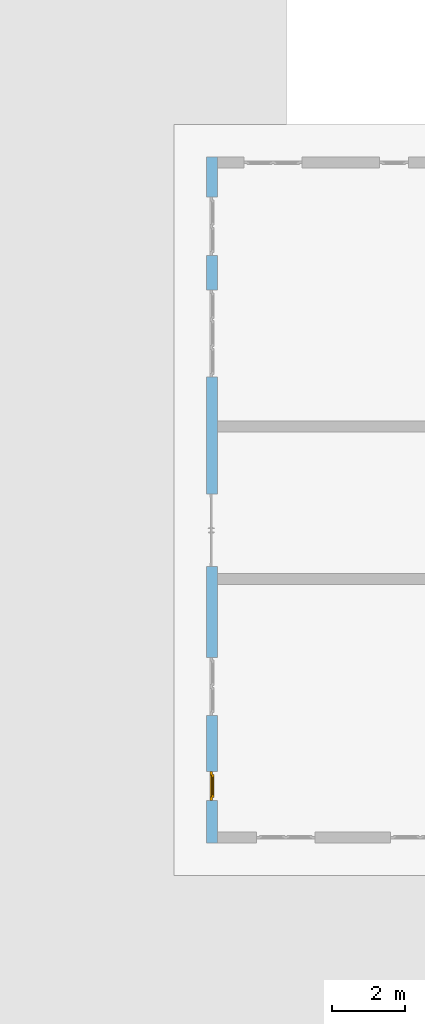
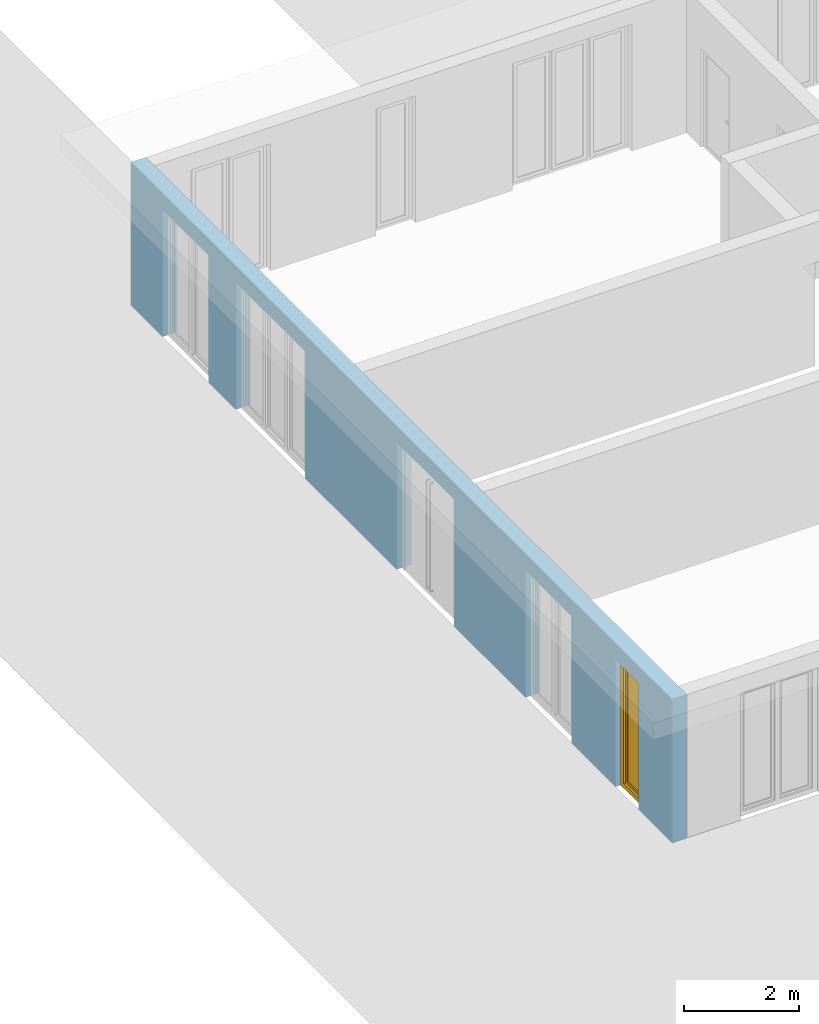
# One storey, part 10 of 23: 1 window, 5 openings, plus 1 element that does not belong to this part.
"""IFC4 building model written with IfcOpenShell, lengths in metres."""

from ifc_helpers import new_model, entity, si_unit, converted_unit, derived_unit, direction, frame, origin_with_axes, place, context, subcontext, project, spatial, polygons, source, transform, mapped, material, type_object, element, fill, save


model = new_model("IFC4")

# Units and contexts
model_context = context("Model", 3, precision=1e-05, world=origin_with_axes(), true_north=direction((0.0, 1.0)))
body_context = subcontext(model_context, "Body", "Model", "MODEL_VIEW")
ifc_project = project(units=[si_unit("LENGTHUNIT", "METRE"), si_unit("AREAUNIT", "SQUARE_METRE"), si_unit("VOLUMEUNIT", "CUBIC_METRE"), converted_unit("PLANEANGLEUNIT", "DEGREE", entity("IfcPlaneAngleMeasure", 0.0174532925199), si_unit("PLANEANGLEUNIT", "RADIAN"), dimensions=[0, 0, 0, 0, 0, 0, 0]), converted_unit("TIMEUNIT", "Year", entity("IfcTimeMeasure", 31556926.0), si_unit("TIMEUNIT", "SECOND"), dimensions=[0, 0, 1, 0, 0, 0, 0]), si_unit("MASSUNIT", "GRAM", prefix="KILO"), si_unit("THERMODYNAMICTEMPERATUREUNIT", "DEGREE_CELSIUS"), si_unit("LUMINOUSINTENSITYUNIT", "LUMEN"), si_unit("ENERGYUNIT", "JOULE", prefix="MEGA"), derived_unit("THERMALCONDUCTANCEUNIT", [(si_unit("POWERUNIT", "WATT"), 1), (si_unit("LENGTHUNIT", "METRE"), -1), (si_unit("THERMODYNAMICTEMPERATUREUNIT", "KELVIN"), -1)]), derived_unit("SPECIFICHEATCAPACITYUNIT", [(si_unit("ENERGYUNIT", "JOULE"), 1), (si_unit("MASSUNIT", "GRAM", prefix="KILO"), -1), (si_unit("THERMODYNAMICTEMPERATUREUNIT", "KELVIN"), -1)]), derived_unit("MASSDENSITYUNIT", [(si_unit("MASSUNIT", "GRAM", prefix="KILO"), 1), (si_unit("VOLUMEUNIT", "CUBIC_METRE"), -1)])], contexts=[model_context])

# Site, building, storey
site_placement = place(None, origin_with_axes())
site = spatial("IfcSite", under=ifc_project, at=site_placement, CompositionType="ELEMENT")
building_placement = place(site_placement, origin_with_axes())
building = spatial("IfcBuilding", under=site, at=building_placement, CompositionType="ELEMENT")
storey_placement = place(building_placement, origin_with_axes())
storey = spatial("IfcBuildingStorey", under=building, at=storey_placement, Name="0. Geschoss", CompositionType="ELEMENT", Elevation=0.0)

# Wall, openings, window
ifc_material = material()
wall_type = type_object("IfcWallType", Name="300", PredefinedType="NOTDEFINED")
wall_placement = place(storey_placement, frame((-11.7421993804, -9.92881223104, 0.0), z_axis=(0.0, 0.0, 1.0), x_axis=(0.0, 1.0, 0.0)))
wall = element("IfcWall", 1, at=wall_placement, inside=storey, type_object=wall_type, material=ifc_material, Name="Wand-001", PredefinedType="NOTDEFINED", context=body_context, shape_type="Tessellation", body=[
    polygons([(7.5921181063, -0.3, 0.0), (7.5921181063, -0.3, 2.7), (9.5921181063, -0.3, 2.7), (9.5921181063, -0.3, 0.0), (12.8, -0.3, 0.0), (12.8, -0.3, 2.7), (15.2, -0.3, 2.7), (15.2, -0.3, 0.0), (16.15, -0.3, 0.0), (16.15, -0.3, 2.7), (17.75, -0.3, 2.7), (17.75, -0.3, 0.0), (18.85, -0.3, 0.0), (18.85, -0.3, 3.05), (0.0, -0.3, 3.05), (0.0, -0.3, 0.0), (1.16441876325, -0.3, 0.0), (1.16441876325, -0.3, 2.7), (1.96441876325, -0.3, 2.7), (1.96441876325, -0.3, 0.0), (3.5, -0.3, 0.0), (3.5, -0.3, 2.7), (5.1, -0.3, 2.7), (5.1, -0.3, 0.0), (7.5921181063, -0.1, 0.0), (7.5921181063, -0.1, 2.7), (9.5921181063, -0.1, 2.7), (9.5921181063, -0.1, 0.0), (9.5921181063, 0.0, 0.0), (12.8, 0.0, 0.0), (12.8, -0.1, 0.0), (12.8, -0.1, 2.7), (15.2, -0.1, 2.7), (15.2, -0.1, 0.0), (15.2, 0.0, 0.0), (16.15, 0.0, 0.0), (16.15, -0.1, 0.0), (16.15, -0.1, 2.7), (17.75, -0.1, 2.7), (17.75, -0.1, 0.0), (17.75, 0.0, 0.0), (18.85, 0.0, 0.0), (18.85, 0.0, 3.05), (0.0, 0.0, 3.05), (0.0, 0.0, 0.0), (1.16441876325, 0.0, 0.0), (1.16441876325, -0.1, 0.0), (1.16441876325, -0.1, 2.7), (1.96441876325, -0.1, 2.7), (1.96441876325, -0.1, 0.0), (1.96441876325, 0.0, 0.0), (3.5, 0.0, 0.0), (3.5, -0.1, 0.0), (3.5, -0.1, 2.7), (5.1, -0.1, 2.7), (5.1, -0.1, 0.0), (5.1, 0.0, 0.0), (7.5921181063, 0.0, 0.0), (7.5921181063, 0.0, 2.7), (9.5921181063, 0.0, 2.7), (5.1, 0.0, 2.7), (3.5, 0.0, 2.7), (1.96441876325, 0.0, 2.7), (1.16441876325, 0.0, 2.7), (17.75, 0.0, 2.7), (16.15, 0.0, 2.7), (15.2, 0.0, 2.7), (12.8, 0.0, 2.7)], [[[1, 2, 3, 4, 5, 6, 7, 8, 9, 10, 11, 12, 13, 14, 15, 16, 17, 18, 19, 20, 21, 22, 23, 24]], [[2, 1, 25, 26]], [[3, 2, 26, 27]], [[4, 3, 27, 28]], [[4, 28, 29, 30, 31, 5]], [[31, 32, 6, 5]], [[32, 33, 7, 6]], [[33, 34, 8, 7]], [[8, 34, 35, 36, 37, 9]], [[10, 9, 37, 38]], [[11, 10, 38, 39]], [[12, 11, 39, 40]], [[40, 41, 42, 13, 12]], [[14, 13, 42, 43]], [[14, 43, 44, 15]], [[44, 45, 16, 15]], [[46, 47, 17, 16, 45]], [[47, 48, 18, 17]], [[48, 49, 19, 18]], [[49, 50, 20, 19]], [[20, 50, 51, 52, 53, 21]], [[22, 21, 53, 54]], [[23, 22, 54, 55]], [[24, 23, 55, 56]], [[25, 1, 24, 56, 57, 58]], [[26, 25, 58, 59]], [[27, 26, 59, 60]], [[28, 27, 60, 29]], [[30, 29, 60, 59, 58, 57, 61, 62, 52, 51, 63, 64, 46, 45, 44, 43, 42, 41, 65, 66, 36, 35, 67, 68]], [[30, 68, 32, 31]], [[68, 67, 33, 32]], [[67, 35, 34, 33]], [[38, 37, 36, 66]], [[39, 38, 66, 65]], [[40, 39, 65, 41]], [[46, 64, 48, 47]], [[64, 63, 49, 48]], [[63, 51, 50, 49]], [[54, 53, 52, 62]], [[55, 54, 62, 61]], [[56, 55, 61, 57]]], closed=True),
])
opening_1_placement = place(wall_placement, frame((16.95, 0.0, 0.0), z_axis=(0.0, 0.0, 1.0), x_axis=(1.0, 0.0, 0.0)))
element("IfcOpeningElement", 2, at=opening_1_placement, cuts=wall, Name="Fenster-001", context=body_context, identifier="Reference", shape_type="Tessellation", body=[
    polygons([(-0.8, -0.1, 0.0), (-0.8, -0.1, 2.7), (-0.8, 0.000999999999999, 2.7), (-0.8, 0.000999999999999, 0.0), (-0.8, -0.301, 0.0), (-0.8, -0.301, 2.7), (0.8, -0.1, 2.7), (0.8, 0.000999999999999, 2.7), (0.8, -0.301, 2.7), (0.8, 0.000999999999999, 0.0), (0.8, -0.1, 0.0), (0.8, -0.301, 0.0)], [[[1, 2, 3, 4]], [[2, 1, 5, 6]], [[7, 8, 3, 2, 6, 9]], [[8, 10, 4, 3]], [[1, 4, 10, 11, 12, 5]], [[6, 5, 12, 9]], [[7, 11, 10, 8]], [[11, 7, 9, 12]]], closed=True),
])
opening_2_placement = place(wall_placement, frame((14.0, 0.0, 0.0), z_axis=(0.0, 0.0, 1.0), x_axis=(1.0, 0.0, 0.0)))
element("IfcOpeningElement", 3, at=opening_2_placement, cuts=wall, Name="Fenster-002", context=body_context, identifier="Reference", shape_type="Tessellation", body=[
    polygons([(-1.2, -0.1, 0.0), (-1.2, -0.1, 2.7), (-1.2, 0.000999999999999, 2.7), (-1.2, 0.000999999999999, 0.0), (-1.2, -0.301, 0.0), (-1.2, -0.301, 2.7), (1.2, -0.1, 2.7), (1.2, 0.000999999999999, 2.7), (1.2, -0.301, 2.7), (1.2, 0.000999999999999, 0.0), (1.2, -0.1, 0.0), (1.2, -0.301, 0.0)], [[[1, 2, 3, 4]], [[2, 1, 5, 6]], [[7, 8, 3, 2, 6, 9]], [[8, 10, 4, 3]], [[1, 4, 10, 11, 12, 5]], [[6, 5, 12, 9]], [[7, 11, 10, 8]], [[11, 7, 9, 12]]], closed=True),
])
opening_3_placement = place(wall_placement, frame((4.3, 0.0, 0.0), z_axis=(0.0, 0.0, 1.0), x_axis=(1.0, 0.0, 0.0)))
element("IfcOpeningElement", 4, at=opening_3_placement, cuts=wall, Name="Fenster-001", context=body_context, identifier="Reference", shape_type="Tessellation", body=[
    polygons([(-0.8, -0.1, 0.0), (-0.8, -0.1, 2.7), (-0.8, 0.000999999999999, 2.7), (-0.8, 0.000999999999999, 0.0), (-0.8, -0.301, 0.0), (-0.8, -0.301, 2.7), (0.8, -0.1, 2.7), (0.8, 0.000999999999999, 2.7), (0.8, -0.301, 2.7), (0.8, 0.000999999999999, 0.0), (0.8, -0.1, 0.0), (0.8, -0.301, 0.0)], [[[1, 2, 3, 4]], [[2, 1, 5, 6]], [[7, 8, 3, 2, 6, 9]], [[8, 10, 4, 3]], [[1, 4, 10, 11, 12, 5]], [[6, 5, 12, 9]], [[7, 11, 10, 8]], [[11, 7, 9, 12]]], closed=True),
])
opening_4_placement = place(wall_placement, frame((1.56441876325, 0.0, 0.0), z_axis=(0.0, 0.0, 1.0), x_axis=(1.0, 0.0, 0.0)))
opening_4 = element("IfcOpeningElement", 5, at=opening_4_placement, cuts=wall, Name="Fenster-003", context=body_context, identifier="Reference", shape_type="Tessellation", body=[
    polygons([(-0.4, -0.1, 0.0), (-0.4, -0.1, 2.7), (-0.4, 0.000999999999999, 2.7), (-0.4, 0.000999999999999, 0.0), (-0.4, -0.301, 0.0), (-0.4, -0.301, 2.7), (0.4, -0.1, 2.7), (0.4, 0.000999999999999, 2.7), (0.4, -0.301, 2.7), (0.4, 0.000999999999999, 0.0), (0.4, -0.1, 0.0), (0.4, -0.301, 0.0)], [[[1, 2, 3, 4]], [[2, 1, 5, 6]], [[7, 8, 3, 2, 6, 9]], [[8, 10, 4, 3]], [[1, 4, 10, 11, 12, 5]], [[6, 5, 12, 9]], [[7, 11, 10, 8]], [[11, 7, 9, 12]]], closed=True),
])
opening_5_placement = place(wall_placement, frame((8.5921181063, 0.0, 0.0), z_axis=(0.0, 0.0, 1.0), x_axis=(1.0, 0.0, 0.0)))
element("IfcOpeningElement", 6, at=opening_5_placement, cuts=wall, context=body_context, identifier="Reference", shape_type="Tessellation", body=[
    polygons([(-1.0, -0.1, 0.0), (-1.0, -0.1, 2.7), (-1.0, 0.000999999999999, 2.7), (-1.0, 0.000999999999999, 0.0), (-1.0, -0.301, 0.0), (-1.0, -0.301, 2.7), (1.0, -0.1, 2.7), (1.0, 0.000999999999999, 2.7), (1.0, -0.301, 2.7), (1.0, 0.000999999999999, 0.0), (1.0, -0.1, 0.0), (1.0, -0.301, 0.0)], [[[1, 2, 3, 4]], [[2, 1, 5, 6]], [[7, 8, 3, 2, 6, 9]], [[8, 10, 4, 3]], [[1, 4, 10, 11, 12, 5]], [[6, 5, 12, 9]], [[7, 11, 10, 8]], [[11, 7, 9, 12]]], closed=True),
])
window_type = type_object("IfcWindowType", Name="1-26", PartitioningType="SINGLE_PANEL", PredefinedType="WINDOW")
shared_shape = source(origin_with_axes(), body_context, "Body", "Tessellation", [
    polygons([(-0.4, -0.07, 0.0), (-0.4, 0.0, 0.0), (-0.3, 0.0, 0.1), (-0.3, -0.07, 0.1), (-0.4, -0.07, 2.7), (-0.4, 0.0, 2.7), (-0.3, 0.0, 2.6), (-0.3, -0.07, 2.6)], [[[1, 2, 3, 4]], [[5, 6, 2, 1]], [[2, 6, 7, 3]], [[4, 3, 7, 8]], [[1, 4, 8, 5]], [[8, 7, 6, 5]]], closed=True),
    polygons([(0.4, -0.07, 0.0), (0.4, 0.0, 0.0), (0.4, 0.0, 2.7), (0.4, -0.07, 2.7), (0.3, -0.07, 0.1), (0.3, 0.0, 0.1), (0.3, 0.0, 2.6), (0.3, -0.07, 2.6)], [[[1, 2, 3, 4]], [[5, 6, 2, 1]], [[2, 6, 7, 3]], [[4, 3, 7, 8]], [[1, 4, 8, 5]], [[8, 7, 6, 5]]], closed=True),
    polygons([(-0.4, -0.07, 0.0), (-0.4, 0.0, 0.0), (0.4, 0.0, 0.0), (0.4, -0.07, 0.0), (-0.3, -0.07, 0.1), (-0.3, 0.0, 0.1), (0.0, 0.0, 0.1), (0.3, 0.0, 0.1), (0.3, -0.07, 0.1), (0.0, -0.07, 0.1)], [[[1, 2, 3, 4]], [[5, 6, 2, 1]], [[2, 6, 7, 8, 3]], [[4, 3, 8, 9]], [[1, 4, 9, 10, 5]], [[10, 7, 6, 5]], [[9, 8, 7, 10]]], closed=True),
    polygons([(-0.4, -0.07, 2.7), (-0.4, 0.0, 2.7), (-0.3, 0.0, 2.6), (-0.3, -0.07, 2.6), (0.4, -0.07, 2.7), (0.4, 0.0, 2.7), (0.3, 0.0, 2.6), (0.0, 0.0, 2.6), (0.0, -0.07, 2.6), (0.3, -0.07, 2.6)], [[[1, 2, 3, 4]], [[5, 6, 2, 1]], [[2, 6, 7, 8, 3]], [[4, 3, 8, 9]], [[1, 4, 9, 10, 5]], [[10, 7, 6, 5]], [[9, 8, 7, 10]]], closed=True),
    polygons([(-0.32, 0.0, 0.08), (-0.32, 0.03, 0.08), (-0.25, 0.03, 0.15), (-0.25, 0.0, 0.15), (-0.32, 0.0, 2.62), (-0.32, 0.03, 2.62), (-0.25, 0.03, 2.55), (-0.25, 0.0, 2.55)], [[[1, 2, 3, 4]], [[5, 6, 2, 1]], [[2, 6, 7, 3]], [[4, 3, 7, 8]], [[1, 4, 8, 5]], [[8, 7, 6, 5]]], closed=True),
    polygons([(0.32, 0.0, 0.08), (0.25, 0.0, 0.15), (0.25, 0.03, 0.15), (0.32, 0.03, 0.08), (0.32, 0.0, 2.62), (0.25, 0.0, 2.55), (0.25, 0.03, 2.55), (0.32, 0.03, 2.62)], [[[1, 2, 3, 4]], [[1, 5, 6, 2]], [[2, 6, 7, 3]], [[4, 3, 7, 8]], [[5, 1, 4, 8]], [[6, 5, 8, 7]]], closed=True),
    polygons([(-0.32, 0.0, 0.08), (-0.32, 0.03, 0.08), (0.32, 0.03, 0.08), (0.32, 0.0, 0.08), (-0.25, 0.0, 0.15), (-0.25, 0.03, 0.15), (0.25, 0.03, 0.15), (0.25, 0.0, 0.15)], [[[1, 2, 3, 4]], [[5, 6, 2, 1]], [[2, 6, 7, 3]], [[4, 3, 7, 8]], [[1, 4, 8, 5]], [[8, 7, 6, 5]]], closed=True),
    polygons([(-0.32, 0.0, 2.62), (0.32, 0.0, 2.62), (0.32, 0.03, 2.62), (-0.32, 0.03, 2.62), (-0.25, 0.0, 2.55), (0.25, 0.0, 2.55), (0.25, 0.03, 2.55), (-0.25, 0.03, 2.55)], [[[1, 2, 3, 4]], [[1, 5, 6, 2]], [[2, 6, 7, 3]], [[4, 3, 7, 8]], [[5, 1, 4, 8]], [[6, 5, 8, 7]]], closed=True),
    polygons([(-0.3, -0.03, 0.1), (-0.3, 0.0, 0.1), (-0.25, 0.0, 0.15), (-0.25, -0.03, 0.15), (-0.3, -0.03, 2.6), (-0.3, 0.0, 2.6), (-0.25, 0.0, 2.55), (-0.25, -0.03, 2.55)], [[[1, 2, 3, 4]], [[5, 6, 2, 1]], [[2, 6, 7, 3]], [[4, 3, 7, 8]], [[1, 4, 8, 5]], [[8, 7, 6, 5]]], closed=True),
    polygons([(0.3, -0.03, 0.1), (0.25, -0.03, 0.15), (0.25, 0.0, 0.15), (0.3, 0.0, 0.1), (0.3, -0.03, 2.6), (0.25, -0.03, 2.55), (0.25, 0.0, 2.55), (0.3, 0.0, 2.6)], [[[1, 2, 3, 4]], [[1, 5, 6, 2]], [[2, 6, 7, 3]], [[4, 3, 7, 8]], [[5, 1, 4, 8]], [[6, 5, 8, 7]]], closed=True),
    polygons([(-0.3, -0.03, 0.1), (-0.3, 0.0, 0.1), (0.3, 0.0, 0.1), (0.3, -0.03, 0.1), (-0.25, -0.03, 0.15), (-0.25, 0.0, 0.15), (0.25, 0.0, 0.15), (0.25, -0.03, 0.15)], [[[1, 2, 3, 4]], [[5, 6, 2, 1]], [[2, 6, 7, 3]], [[4, 3, 7, 8]], [[1, 4, 8, 5]], [[8, 7, 6, 5]]], closed=True),
    polygons([(-0.3, -0.03, 2.6), (0.3, -0.03, 2.6), (0.3, 0.0, 2.6), (-0.3, 0.0, 2.6), (-0.25, -0.03, 2.55), (0.25, -0.03, 2.55), (0.25, 0.0, 2.55), (-0.25, 0.0, 2.55)], [[[1, 2, 3, 4]], [[1, 5, 6, 2]], [[2, 6, 7, 3]], [[4, 3, 7, 8]], [[5, 1, 4, 8]], [[6, 5, 8, 7]]], closed=True),
    polygons([(-0.25, -0.005, 0.15), (-0.25, 0.005, 0.15), (0.25, 0.005, 0.15), (0.25, -0.005, 0.15), (-0.25, -0.005, 2.55), (-0.25, 0.005, 2.55), (0.25, 0.005, 2.55), (0.25, -0.005, 2.55)], [[[1, 2, 3, 4]], [[5, 6, 2, 1]], [[2, 6, 7, 3]], [[4, 3, 7, 8]], [[1, 4, 8, 5]], [[8, 7, 6, 5]]], closed=True),
])
window_placement = place(opening_4_placement, frame((0.4, 0.0, 0.0), z_axis=(0.0, 0.0, 1.0), x_axis=(-1.0, 0.0, 0.0)))
window = element("IfcWindow", 7, at=window_placement, inside=storey, type_object=window_type, Name="Fenster-003", OverallHeight=2.7, OverallWidth=0.8, PredefinedType="WINDOW", context=body_context, shape_type="MappedRepresentation", body=[
    mapped(shared_shape, transform((0.4, 0.17, 0.0))),
])
fill(opening_4, window)

save(model, "model.ifc")
